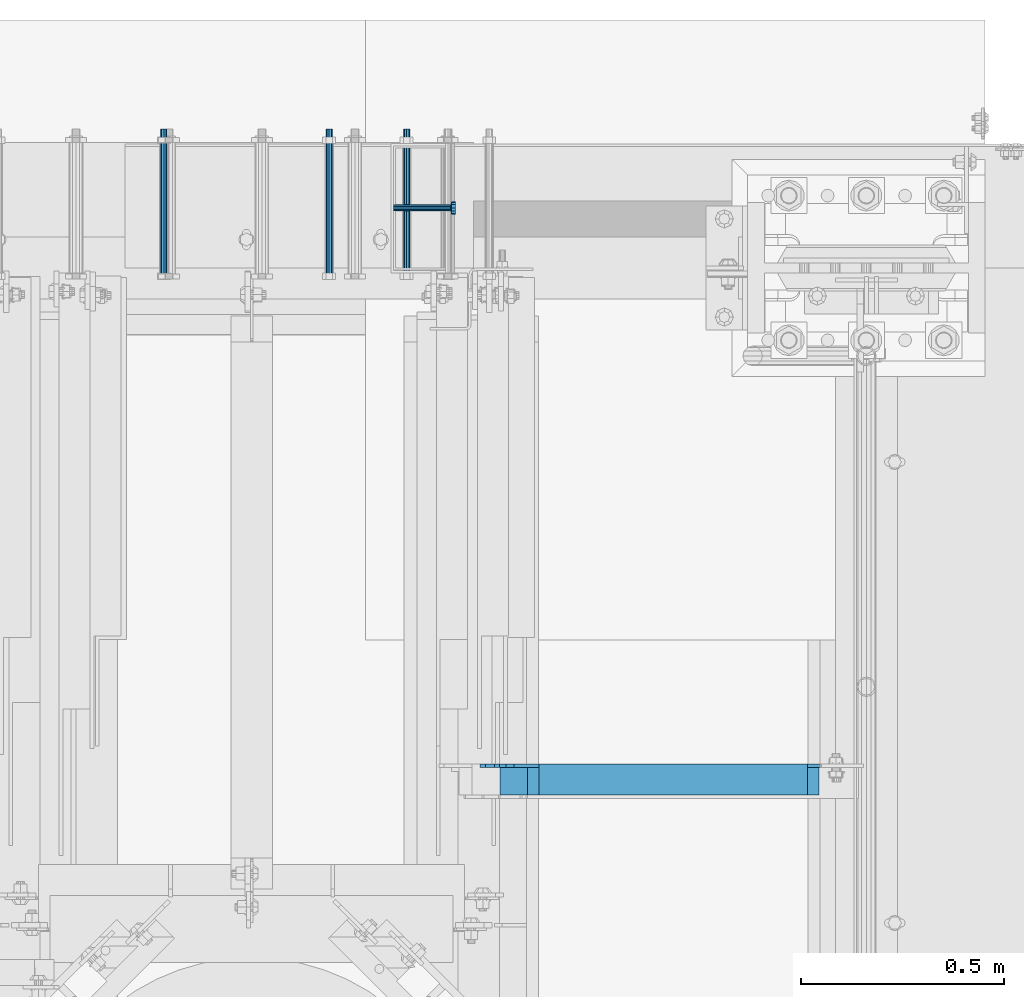
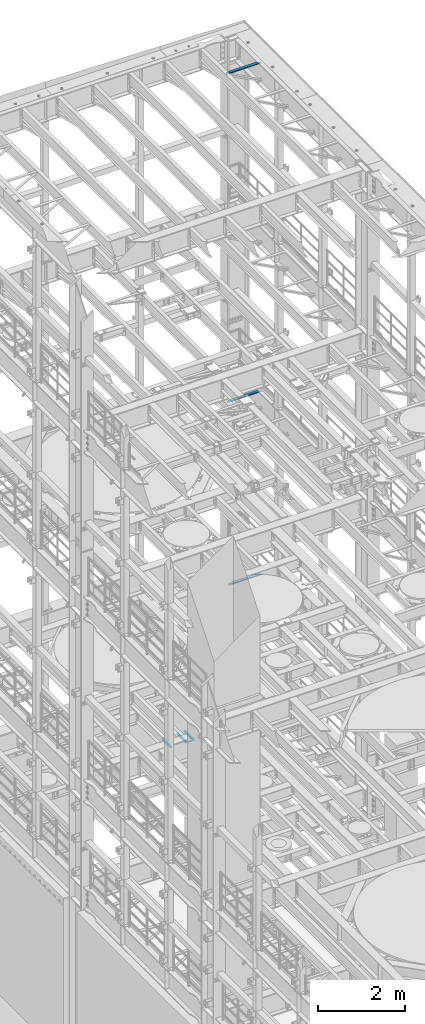
# One storey, part 1329 of 1876: 7 beams, 7 elements without a shape of their own.
"""IFC2X3 building model written with IfcOpenShell, lengths in millimetres."""

from ifc_helpers import new_model, si_unit, frame, origin_with_axes, place, context, subcontext, project, spatial, faceted_brep, material, type_object, element, aggregate, save


model = new_model("IFC2X3")

# Units and contexts
model_context = context("Model", 3, precision=1e-05, world=origin_with_axes())
body_context = subcontext(model_context, "Body", "Model", "MODEL_VIEW")
ifc_project = project(units=[si_unit("LENGTHUNIT", "METRE", prefix="MILLI"), si_unit("AREAUNIT", "SQUARE_METRE"), si_unit("VOLUMEUNIT", "CUBIC_METRE"), si_unit("MASSUNIT", "GRAM", prefix="KILO"), si_unit("TIMEUNIT", "SECOND"), si_unit("PLANEANGLEUNIT", "RADIAN"), si_unit("SOLIDANGLEUNIT", "STERADIAN"), si_unit("THERMODYNAMICTEMPERATUREUNIT", "DEGREE_CELSIUS"), si_unit("LUMINOUSINTENSITYUNIT", "LUMEN")], contexts=[model_context])

# Site, building, storey
site_placement = place(None, origin_with_axes())
site = spatial("IfcSite", under=ifc_project, at=site_placement, CompositionType="ELEMENT")
building_placement = place(site_placement, origin_with_axes())
building = spatial("IfcBuilding", under=site, at=building_placement, Name="Undefined", CompositionType="ELEMENT")
storey_placement = place(building_placement, origin_with_axes())
storey = spatial("IfcBuildingStorey", under=building, at=storey_placement, Name="Undefined", CompositionType="ELEMENT", Elevation=0.0)

# Assembly, beam
assembly_1_placement = place(storey_placement, origin_with_axes())
assembly_1 = element("IfcElementAssembly", 1, at=assembly_1_placement, inside=storey, Name="ANGLE", AssemblyPlace="NOTDEFINED", PredefinedType="RIGID_FRAME")
ifc_material_1 = material(Name="STEEL/A36")
beam_type_1 = type_object("IfcBeamType", Name="L3X3X3/8", PredefinedType="NOTDEFINED")
beam_1_placement = place(assembly_1_placement, frame((6667.50000000002, 12458.7, 22517.1000001129), z_axis=(0.0, -1.0, 0.0), x_axis=(1.0, 0.0, 0.0)))
beam_1 = element("IfcBeam", 2, at=beam_1_placement, type_object=beam_type_1, material=ifc_material_1, Name="ANGLE", ObjectType="L3X3X3/8", context=body_context, shape_type="Brep", body=[
    faceted_brep([(836.613000301995, 28.5750000000007, -28.5749999999998), (836.613001168791, 28.5750000000007, 38.0999999999999), (52.3870335430847, 28.5750001907327, 38.0999999999858), (52.3869956588824, 28.5749999999955, -28.5750000000007), (836.613001168791, 38.0999999999985, 38.0999999999999), (52.387033543122, 38.0999999999985, 38.0999999999858), (15.8749936676099, 28.5749999999989, -28.5750000000007), (15.8749999382144, 28.5750001907327, -38.0999999999999), (3.17500012894925, 15.8750003814675, -38.0999999999999), (3.17500032897624, 15.8750003814675, -28.5749999999998), (52.3870393343063, 28.5750001907327, -38.1000000000149), (52.3869953826566, 38.0999999999954, -38.0999999999985), (836.613000178167, 38.0999999999985, -38.0999999999999), (836.613000301995, 12.6999991241828, -28.5749999999998), (836.613000178167, 12.6999991241828, -38.0999999999999), (913.60625591723, 12.6999991241828, -28.5749999999998), (913.606255793401, 12.6999991241828, -38.0999999999999), (945.35625591723, -19.0500008758172, -28.5749999999998), (945.356255793401, -19.0500008758172, -38.0999999999999), (945.356249999983, -38.0999999999985, -28.5749999999998), (945.356249999983, -38.0999999999985, -38.0999999999999), (3.17499999075153, -38.0999999999985, -28.5749999999998), (3.17499999075153, -38.0999999999985, -38.0999999999999), (3.17500012894925, 3.17500152587672, -38.0999999999999), (3.17500032897624, 3.17500152587672, -28.5749999999998)], [[[0, 1, 2, 3]], [[1, 4, 5, 2]], [[6, 7, 8, 9]], [[3, 10, 7, 6]], [[2, 5, 11, 10, 3]], [[4, 12, 11, 5]], [[1, 0, 13, 14, 12, 4]], [[15, 16, 14, 13]], [[16, 15, 17, 18]], [[18, 17, 19, 20]], [[20, 19, 21, 22]], [[8, 7, 10, 11, 12, 14, 16, 18, 20, 22, 23]], [[9, 8, 23, 24]], [[19, 17, 15, 13, 0, 3, 6, 9, 24, 21]], [[23, 22, 21, 24]]]),
])
aggregate(assembly_1, [beam_1])

assembly_2_placement = place(storey_placement, origin_with_axes())
assembly_2 = element("IfcElementAssembly", 3, at=assembly_2_placement, inside=storey, Name="ANGLE", AssemblyPlace="NOTDEFINED", PredefinedType="RIGID_FRAME")
beam_2_placement = place(assembly_2_placement, frame((6730.99999999938, 12458.7, 8115.3), z_axis=(0.0, -1.0, 0.0), x_axis=(1.0, 0.0, 0.0)))
beam_2 = element("IfcBeam", 4, at=beam_2_placement, type_object=beam_type_1, material=ifc_material_1, Name="ANGLE", ObjectType="L3X3X3/8", context=body_context, shape_type="Brep", body=[
    faceted_brep([(744.538000225918, 28.5749999999998, -28.5750000000007), (744.538000959305, 28.5749999999998, 38.1000000000004), (84.1370686928021, 28.5750001907327, 38.100000000024), (84.1370606917826, 28.5750000000007, -28.5749999999771), (744.538000959288, 38.1000000000004, 38.1000000000004), (84.1374011325761, 38.0999999999985, 38.0999999999776), (22.2249552881549, 26.9870083863452, -28.5749999999935), (22.2249551643299, 26.9870094055232, -38.0999999999931), (3.17495592726937, 7.93701016846171, -38.0999999999995), (3.17495605109434, 7.93700914928468, -28.5749999999989), (84.1369575769495, 26.9870083863452, -28.5749999999744), (84.1369574531245, 26.9870094055223, -38.099999999974), (84.137408980816, 38.0999999999985, -38.1000000000231), (744.538000121132, 38.1000000000004, -38.1000000000004), (744.538000225876, 14.2869991302496, -28.5750000000007), (744.538000121098, 14.2869991302496, -38.1000000000004), (856.456253170776, 14.2869991302496, -28.5750000000007), (856.456253065998, 14.2869991302496, -38.1000000000004), (881.856252789306, -11.1130004882807, -28.5750000000007), (881.856252684528, -11.1130004882807, -38.1000000000004), (881.856250000624, -38.1000000000004, -28.5750000000007), (881.856250000624, -38.1000000000004, -38.1000000000004), (3.17499999075153, -38.0999999999985, -28.5749999999998), (3.17499999075153, -38.0999999999985, -38.0999999999999), (3.17495592726937, 1.58700978699198, -38.0999999999995), (3.17495605109434, 1.58700876781495, -28.5749999999989)], [[[0, 1, 2, 3]], [[1, 4, 5, 2]], [[6, 7, 8, 9]], [[10, 11, 7, 6]], [[2, 5, 12, 11, 10, 3]], [[4, 13, 12, 5]], [[1, 0, 14, 15, 13, 4]], [[16, 17, 15, 14]], [[17, 16, 18, 19]], [[19, 18, 20, 21]], [[21, 20, 22, 23]], [[8, 7, 11, 12, 13, 15, 17, 19, 21, 23, 24]], [[9, 8, 24, 25]], [[20, 18, 16, 14, 0, 3, 10, 6, 9, 25, 22]], [[24, 23, 22, 25]]]),
])
aggregate(assembly_2, [beam_2])

assembly_3_placement = place(storey_placement, origin_with_axes())
assembly_3 = element("IfcElementAssembly", 5, at=assembly_3_placement, inside=storey, Name="ANGLE", AssemblyPlace="NOTDEFINED", PredefinedType="RIGID_FRAME")
beam_3_placement = place(assembly_3_placement, frame((6702.425, 12458.7, 13271.5), z_axis=(0.0, -1.0, 0.0), x_axis=(1.0, 0.0, 0.0)))
beam_3 = element("IfcBeam", 6, at=beam_3_placement, type_object=beam_type_1, material=ifc_material_1, Name="ANGLE", ObjectType="L3X3X3/8", context=body_context, shape_type="Brep", body=[
    faceted_brep([(801.68800030201, 28.5750000000007, -28.5750000000007), (801.688001168805, 28.5750000000007, 38.1000000000004), (84.137014014791, 28.5749999999998, 38.1000000000258), (84.1370001605219, 28.5749999999998, -28.5750000000007), (801.688001168805, 38.1000000000004, 38.1000000000004), (84.136999759924, 38.0999999999985, 38.0999999999999), (15.8750004498515, 25.4000000000005, -28.5750000000007), (15.8750002879233, 25.4000000000005, -38.1000000000004), (3.17500047865815, 12.7000001907354, -38.1000000000004), (3.1750006405864, 12.7000001907354, -28.5750000000007), (84.1369986264262, 25.4000000000005, -28.5750000000007), (84.136998464498, 25.4000000000005, -38.1000000000004), (84.1369984645207, 38.0999999999985, -38.0999999999999), (801.688000178181, 38.1000000000004, -38.1000000000004), (801.68800030201, 12.6999992370602, -28.5750000000007), (801.688000178181, 12.6999992370602, -38.1000000000004), (878.681248287849, 12.6999992370602, -28.5750000000007), (878.681248164021, 12.6999992370602, -38.1000000000004), (910.431248287849, -19.0500007629398, -28.5750000000007), (910.431248164021, -19.0500007629398, -38.1000000000004), (910.431249999999, -38.1000000000004, -28.5750000000007), (910.431249999999, -38.1000000000004, -38.1000000000004), (3.17499999075153, -38.0999999999985, -28.5749999999998), (3.17499999075153, -38.0999999999985, -38.0999999999999), (3.17500047865815, -1.52587836055318e-06, -38.1000000000004), (3.1750006405864, -1.52587836055318e-06, -28.5750000000007)], [[[0, 1, 2, 3]], [[1, 4, 5, 2]], [[6, 7, 8, 9]], [[10, 11, 7, 6]], [[2, 5, 12, 11, 10, 3]], [[4, 13, 12, 5]], [[1, 0, 14, 15, 13, 4]], [[16, 17, 15, 14]], [[17, 16, 18, 19]], [[19, 18, 20, 21]], [[21, 20, 22, 23]], [[8, 7, 11, 12, 13, 15, 17, 19, 21, 23, 24]], [[9, 8, 24, 25]], [[20, 18, 16, 14, 0, 3, 10, 6, 9, 25, 22]], [[24, 23, 22, 25]]]),
])
aggregate(assembly_3, [beam_3])

assembly_4_placement = place(storey_placement, origin_with_axes())
assembly_4 = element("IfcElementAssembly", 7, at=assembly_4_placement, inside=storey, Name="ANCHOR_BOLT", AssemblyPlace="NOTDEFINED", PredefinedType="RIGID_FRAME")
beam_type_2 = type_object("IfcBeamType", PredefinedType="NOTDEFINED")
beam_4_placement = place(assembly_4_placement, frame((6489.71071748652, 14057.3124966791, 3103.56250152592), z_axis=(0.0, 0.0, 1.0), x_axis=(-2.91149999864615e-05, -0.999999999576158, 0.0)))
beam_4 = element("IfcBeam", 8, at=beam_4_placement, type_object=beam_type_2, material=ifc_material_1, Name="ANCHOR_BOLT", context=body_context, shape_type="Brep", body=[
    faceted_brep([(0.0, -7.9375, 0.0), (0.0, -5.61266007566822, -5.61266007566883), (369.887490732475, -5.61266007567792, -5.61266007566837), (369.887490732477, -7.93750000000978, 0.0), (0.0, 0.0, -7.9375), (369.88749073247, -9.54969436861575e-12, -7.9375), (0.0, 5.61266007566822, -5.61266007566883), (369.887490732464, 5.6126600756586, -5.61266007566837), (0.0, 7.9375, 0.0), (369.887490732463, 7.93749999999045, 0.0), (0.0, 5.61266007566822, 5.61266007566883), (369.887490732464, 5.6126600756586, 5.61266007566837), (0.0, 0.0, 7.9375), (369.88749073247, -9.54969436861575e-12, 7.9375), (0.0, -5.61266007566822, 5.61266007566883), (369.887490732475, -5.61266007567792, 5.61266007566837)], [[[0, 1, 2, 3]], [[1, 4, 5, 2]], [[4, 6, 7, 5]], [[6, 8, 9, 7]], [[8, 10, 11, 9]], [[10, 12, 13, 11]], [[12, 14, 15, 13]], [[14, 0, 3, 15]], [[5, 7, 9, 11, 13, 15, 3, 2]], [[14, 12, 10, 8, 6, 4, 1, 0]]]),
])
aggregate(assembly_4, [beam_4])

assembly_5_placement = place(storey_placement, origin_with_axes())
assembly_5 = element("IfcElementAssembly", 9, at=assembly_5_placement, inside=storey, Name="ANCHOR_BOLT", AssemblyPlace="NOTDEFINED", PredefinedType="RIGID_FRAME")
beam_5_placement = place(assembly_5_placement, frame((6299.21071748669, 14057.3124966791, 3103.56250152592), z_axis=(0.0, 0.0, 1.0), x_axis=(-2.91149999864615e-05, -0.999999999576158, 0.0)))
beam_5 = element("IfcBeam", 10, at=beam_5_placement, type_object=beam_type_2, material=ifc_material_1, Name="ANCHOR_BOLT", context=body_context, shape_type="Brep", body=[
    faceted_brep([(0.0, -7.9375, 0.0), (0.0, -5.61266007566822, -5.61266007566883), (369.887490732475, -5.61266007567792, -5.61266007566837), (369.887490732477, -7.93750000000978, 0.0), (0.0, 0.0, -7.9375), (369.88749073247, -9.54969436861575e-12, -7.9375), (0.0, 5.61266007566822, -5.61266007566883), (369.887490732464, 5.6126600756586, -5.61266007566837), (0.0, 7.9375, 0.0), (369.887490732463, 7.93749999999045, 0.0), (0.0, 5.61266007566822, 5.61266007566883), (369.887490732464, 5.6126600756586, 5.61266007566837), (0.0, 0.0, 7.9375), (369.88749073247, -9.54969436861575e-12, 7.9375), (0.0, -5.61266007566822, 5.61266007566883), (369.887490732475, -5.61266007567792, 5.61266007566837)], [[[0, 1, 2, 3]], [[1, 4, 5, 2]], [[4, 6, 7, 5]], [[6, 8, 9, 7]], [[8, 10, 11, 9]], [[10, 12, 13, 11]], [[12, 14, 15, 13]], [[14, 0, 3, 15]], [[5, 7, 9, 11, 13, 15, 3, 2]], [[14, 12, 10, 8, 6, 4, 1, 0]]]),
])
aggregate(assembly_5, [beam_5])

assembly_6_placement = place(storey_placement, origin_with_axes())
assembly_6 = element("IfcElementAssembly", 11, at=assembly_6_placement, inside=storey, Name="ANCHOR_BOLT", AssemblyPlace="NOTDEFINED", PredefinedType="RIGID_FRAME")
beam_6_placement = place(assembly_6_placement, frame((5892.81071748669, 14057.3124966791, 3103.56250152592), z_axis=(0.0, 0.0, 1.0), x_axis=(-2.91149999864615e-05, -0.999999999576158, 0.0)))
beam_6 = element("IfcBeam", 12, at=beam_6_placement, type_object=beam_type_2, material=ifc_material_1, Name="ANCHOR_BOLT", context=body_context, shape_type="Brep", body=[
    faceted_brep([(0.0, -7.9375, 0.0), (0.0, -5.61266007566822, -5.61266007566883), (369.887490732475, -5.61266007567792, -5.61266007566837), (369.887490732477, -7.93750000000978, 0.0), (0.0, 0.0, -7.9375), (369.88749073247, -9.54969436861575e-12, -7.9375), (0.0, 5.61266007566822, -5.61266007566883), (369.887490732464, 5.6126600756586, -5.61266007566837), (0.0, 7.9375, 0.0), (369.887490732463, 7.93749999999045, 0.0), (0.0, 5.61266007566822, 5.61266007566883), (369.887490732464, 5.6126600756586, 5.61266007566837), (0.0, 0.0, 7.9375), (369.88749073247, -9.54969436861575e-12, 7.9375), (0.0, -5.61266007566822, 5.61266007566883), (369.887490732475, -5.61266007567792, 5.61266007566837)], [[[0, 1, 2, 3]], [[1, 4, 5, 2]], [[4, 6, 7, 5]], [[6, 8, 9, 7]], [[8, 10, 11, 9]], [[10, 12, 13, 11]], [[12, 14, 15, 13]], [[14, 0, 3, 15]], [[5, 7, 9, 11, 13, 15, 3, 2]], [[14, 12, 10, 8, 6, 4, 1, 0]]]),
])
aggregate(assembly_6, [beam_6])

assembly_7_placement = place(storey_placement, origin_with_axes())
assembly_7 = element("IfcElementAssembly", 13, at=assembly_7_placement, inside=storey, Name="BENT PLATE", AssemblyPlace="NOTDEFINED", PredefinedType="RIGID_FRAME")
ifc_material_2 = material(Name="STEEL/A108")
beam_type_3 = type_object("IfcBeamType", Name="STUD_5/8-DIA", PredefinedType="NOTDEFINED")
beam_7_placement = place(assembly_7_placement, frame((6457.95144692033, 13863.6374842527, 2946.4), z_axis=(0.0, 0.0, 1.0), x_axis=(1.0, 0.0, 0.0)))
beam_7 = element("IfcBeam", 14, at=beam_7_placement, type_object=beam_type_3, material=ifc_material_2, Name="WELDED HEADED STUD", ObjectType="STUD_5/8-DIA", context=body_context, shape_type="Brep", body=[
    faceted_brep([(0.0, -7.94000005722046, 0.0), (0.0, -6.86999988555908, -3.97000002861023), (140.207082738083, -6.86999988555908, -3.97000002861023), (140.207082738083, -7.94000005722046, 0.0), (0.0, -3.97000002861023, -6.86999988555908), (140.207082738083, -3.97000002861023, -6.86999988555908), (0.0, 0.0, -7.94000005722046), (140.207082738083, 0.0, -7.94000005722046), (0.0, 3.97000002861023, -6.86999988555908), (140.207082738083, 3.97000002861023, -6.86999988555908), (0.0, 6.86999988555908, -3.97000002861023), (140.207082738083, 6.86999988555908, -3.97000002861023), (0.0, 7.94000005722046, 0.0), (140.207082738083, 7.94000005722046, 0.0), (0.0, 6.86999988555908, 3.97000002861023), (140.207082738083, 6.86999988555908, 3.97000002861023), (0.0, 3.97000002861023, 6.86999988555908), (140.207082738083, 3.97000002861023, 6.86999988555908), (0.0, 0.0, 7.94000005722046), (140.207082738083, 0.0, 7.94000005722046), (0.0, -3.97000002861023, 6.86999988555908), (140.207082738083, -3.97000002861023, 6.86999988555908), (0.0, -6.86999988555908, 3.97000002861023), (140.207082738083, -6.86999988555908, 3.97000002861023), (141.731072767845, -13.75, -7.94000005722046), (141.731072767845, -15.8800001144409, 0.0), (141.731072767845, -7.94000005722046, -13.75), (141.731072767845, 0.0, -15.8800001144409), (141.731072767845, 7.94000005722046, -13.75), (141.731072767845, 13.75, -7.94000005722046), (141.731072767845, 15.8800001144409, 0.0), (141.731072767845, 13.75, 7.94000005722046), (141.731072767845, 7.94000005722046, 13.75), (141.731072767845, 0.0, 15.8800001144409), (141.731072767845, -7.94000005722046, 13.75), (141.731072767845, -13.75, 7.94000005722046), (152.399002976177, -13.75, -7.94000005722046), (152.399002976177, -15.8800001144409, 0.0), (152.399002976177, -7.94000005722046, -13.75), (152.399002976177, 0.0, -15.8800001144409), (152.399002976177, 7.94000005722046, -13.75), (152.399002976177, 13.75, -7.94000005722046), (152.399002976177, 15.8800001144409, 0.0), (152.399002976177, 13.75, 7.94000005722046), (152.399002976177, 7.94000005722046, 13.75), (152.399002976177, 0.0, 15.8800001144409), (152.399002976177, -7.94000005722046, 13.75), (152.399002976177, -13.75, 7.94000005722046)], [[[0, 1, 2, 3]], [[1, 4, 5, 2]], [[4, 6, 7, 5]], [[6, 8, 9, 7]], [[8, 10, 11, 9]], [[10, 12, 13, 11]], [[12, 14, 15, 13]], [[14, 16, 17, 15]], [[16, 18, 19, 17]], [[18, 20, 21, 19]], [[20, 22, 23, 21]], [[22, 0, 3, 23]], [[22, 20, 18, 16, 14, 12, 10, 8, 6, 4, 1, 0]], [[3, 2, 24, 25]], [[2, 5, 26, 24]], [[5, 7, 27, 26]], [[7, 9, 28, 27]], [[9, 11, 29, 28]], [[11, 13, 30, 29]], [[13, 15, 31, 30]], [[15, 17, 32, 31]], [[17, 19, 33, 32]], [[19, 21, 34, 33]], [[21, 23, 35, 34]], [[23, 3, 25, 35]], [[25, 24, 36, 37]], [[24, 26, 38, 36]], [[26, 27, 39, 38]], [[27, 28, 40, 39]], [[28, 29, 41, 40]], [[29, 30, 42, 41]], [[30, 31, 43, 42]], [[31, 32, 44, 43]], [[32, 33, 45, 44]], [[33, 34, 46, 45]], [[34, 35, 47, 46]], [[35, 25, 37, 47]], [[38, 39, 40, 41, 42, 43, 44, 45, 46, 47, 37, 36]]]),
])
aggregate(assembly_7, [beam_7])

save(model, "model.ifc")
